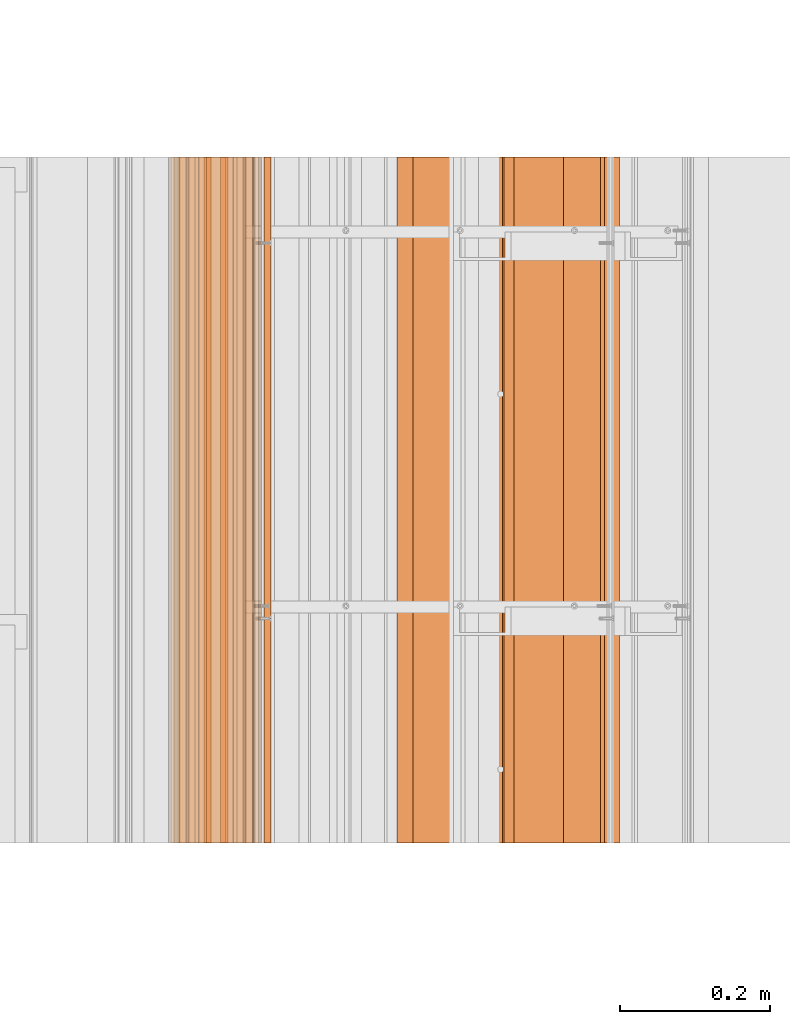
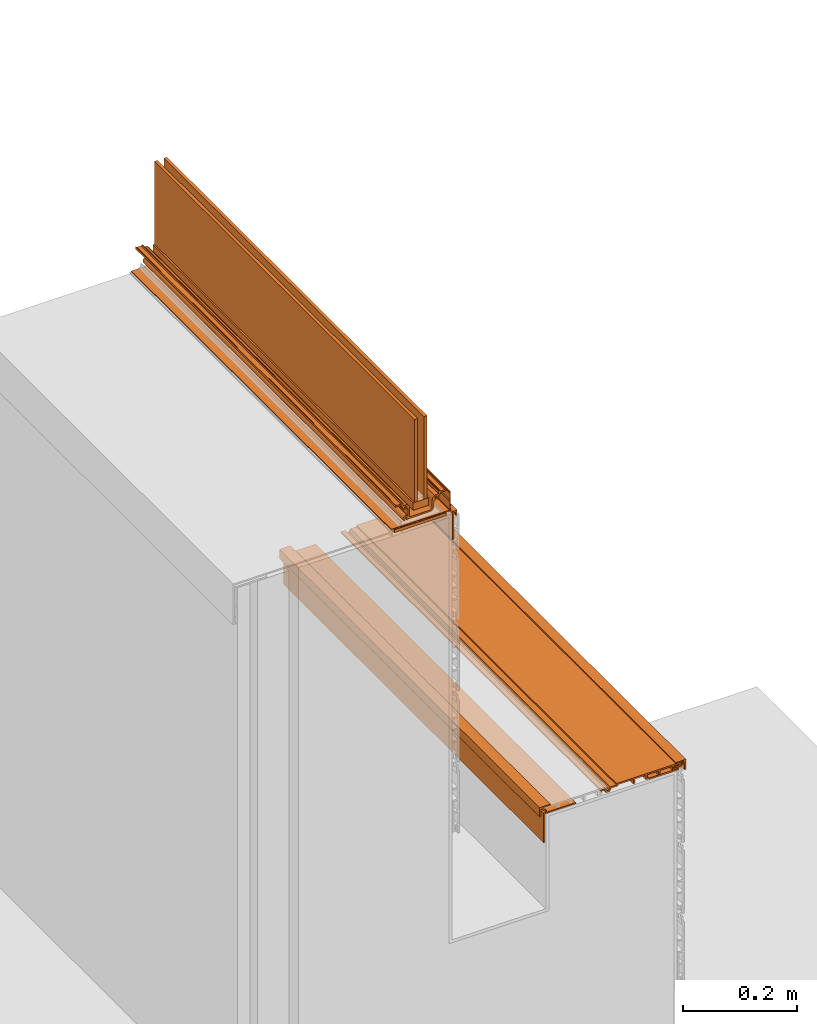
# One storey, part 5 of 36: 12 proxies.
"""IFC2X3 building model written with IfcOpenShell, lengths in feet."""

from ifc_helpers import new_model, entity, si_unit, converted_unit, derived_unit, direction, frame, frame_2d, origin, origin_2d_with_axis, place, context, subcontext, project, spatial, polyline, circle_curve, parameter, trimmed, segment, composite_curve, rectangle, outline, extrude, source, transform, mapped, material, type_object, type_shapes, element, save


model = new_model("IFC2X3")

# Units and contexts
model_context = context("Model", 3, precision=0.0001, world=origin(), true_north=direction((6.12303176911189e-17, 1.0)))
body_context = subcontext(model_context, "Body", "Model", "MODEL_VIEW")
ifc_project = project(units=[converted_unit("LENGTHUNIT", "FOOT", entity("IfcRatioMeasure", 0.3048), si_unit("LENGTHUNIT", "METRE"), dimensions=[1, 0, 0, 0, 0, 0, 0]), converted_unit("AREAUNIT", "SQUARE FOOT", entity("IfcRatioMeasure", 0.09290304), si_unit("AREAUNIT", "SQUARE_METRE"), dimensions=[2, 0, 0, 0, 0, 0, 0]), converted_unit("VOLUMEUNIT", "CUBIC FOOT", entity("IfcRatioMeasure", 0.028316846592), si_unit("VOLUMEUNIT", "CUBIC_METRE"), dimensions=[3, 0, 0, 0, 0, 0, 0]), converted_unit("PLANEANGLEUNIT", "DEGREE", entity("IfcRatioMeasure", 0.0174532925199433), si_unit("PLANEANGLEUNIT", "RADIAN"), dimensions=[0, 0, 0, 0, 0, 0, 0]), si_unit("MASSUNIT", "GRAM", prefix="KILO"), derived_unit("MASSDENSITYUNIT", [(si_unit("MASSUNIT", "GRAM", prefix="KILO"), 1), (si_unit("LENGTHUNIT", "METRE"), -3)]), si_unit("TIMEUNIT", "SECOND"), si_unit("FREQUENCYUNIT", "HERTZ"), si_unit("THERMODYNAMICTEMPERATUREUNIT", "DEGREE_CELSIUS"), derived_unit("THERMALTRANSMITTANCEUNIT", [(si_unit("MASSUNIT", "GRAM", prefix="KILO"), 1), (si_unit("THERMODYNAMICTEMPERATUREUNIT", "KELVIN"), -1), (si_unit("TIMEUNIT", "SECOND"), -3)]), derived_unit("VOLUMETRICFLOWRATEUNIT", [(si_unit("LENGTHUNIT", "METRE"), 3), (si_unit("TIMEUNIT", "SECOND"), -1)]), si_unit("ELECTRICCURRENTUNIT", "AMPERE"), si_unit("ELECTRICVOLTAGEUNIT", "VOLT"), si_unit("POWERUNIT", "WATT"), si_unit("FORCEUNIT", "NEWTON"), si_unit("ILLUMINANCEUNIT", "LUX"), si_unit("LUMINOUSFLUXUNIT", "LUMEN"), si_unit("LUMINOUSINTENSITYUNIT", "CANDELA"), derived_unit("USERDEFINED", [(si_unit("MASSUNIT", "GRAM", prefix="KILO"), -1), (si_unit("LENGTHUNIT", "METRE"), -2), (si_unit("TIMEUNIT", "SECOND"), 3), (si_unit("LUMINOUSFLUXUNIT", "LUMEN"), 1)]), derived_unit("LINEARVELOCITYUNIT", [(si_unit("LENGTHUNIT", "METRE"), 1), (si_unit("TIMEUNIT", "SECOND"), -1)]), si_unit("PRESSUREUNIT", "PASCAL"), derived_unit("USERDEFINED", [(si_unit("LENGTHUNIT", "METRE"), -2), (si_unit("MASSUNIT", "GRAM", prefix="KILO"), 1), (si_unit("TIMEUNIT", "SECOND"), -2)])], contexts=[model_context])

# Site, building, storey
site_placement = place(None, origin())
site = spatial("IfcSite", under=ifc_project, at=site_placement, CompositionType="ELEMENT")
building_placement = place(site_placement, origin())
building = spatial("IfcBuilding", under=site, at=building_placement, CompositionType="ELEMENT")
storey_placement = place(building_placement, origin())
storey = spatial("IfcBuildingStorey", under=building, at=storey_placement, Name="Level 1", CompositionType="ELEMENT", Elevation=0.0)

# Proxies
ifc_material_1 = material(Name="_EXISTING CAST-IN-PLACE CONCRETE")
building_element_proxy_type_1 = type_object("IfcBuildingElementProxyType", Name="starter strip 016", PredefinedType="NOTDEFINED", material=ifc_material_1)
shared_shape_1 = source(origin(), body_context, "Body", "SweptSolid", [
    extrude(outline(polyline([(-0.00592609117454401, -0.050489778625332), (-0.00592609117454401, -0.0251609571030125), (-0.0154211444225609, -0.0251609571030125), (-0.0154211444225609, -0.0613594856463298), (0.0159630966207516, -0.0613594856463298), (0.0159630966207516, 0.137010221374674), (0.005384138976396, 0.137010221374674), (0.005384138976396, -0.050489778625332), (-0.00592609117454401, -0.050489778625332)])), frame((123.583785406736, -64.2284331589239, 4.30650615626973), z_axis=(0.0, -1.0, 0.0), x_axis=(-1.0, 0.0, 0.0)), (0.0, 0.0, -1.0), 3.0),
])
type_shapes(building_element_proxy_type_1, [shared_shape_1])
proxy_1_placement = place(storey_placement, origin())
element("IfcBuildingElementProxy", 1, at=proxy_1_placement, inside=storey, type_object=building_element_proxy_type_1, material=ifc_material_1, Name="starter strip 016:starter strip 016", ObjectType="starter strip 016", context=body_context, shape_type="MappedRepresentation", body=[
    mapped(shared_shape_1, transform((0.0, 0.0, 0.0), scale=1.0)),
])
building_element_proxy_type_2 = type_object("IfcBuildingElementProxyType", Name="starter strip 017", PredefinedType="NOTDEFINED", material=ifc_material_1)
shared_shape_2 = source(origin(), body_context, "Body", "SweptSolid", [
    extrude(outline(polyline([(-0.0154211442749248, -0.0613594857283459), (0.0159630965387136, -0.0613594857283459), (0.0159630965387136, 0.137010221423893), (0.00538413886154165, 0.137010221423893), (0.00538413886154165, -0.0504897785761358), (-0.00592609112533005, -0.0504897785761358), (-0.00592609112533005, -0.0251609571194393), (-0.0154211442749248, -0.0251609571194393), (-0.0154211442749248, -0.0613594857283459)])), frame((125.015685607566, -64.2284331589239, 2.03863767952562), z_axis=(0.0, 1.0, 0.0), x_axis=(0.0, 0.0, -1.0)), (0.0, 0.0, 1.0), 3.0),
])
type_shapes(building_element_proxy_type_2, [shared_shape_2])
proxy_2_placement = place(storey_placement, origin())
element("IfcBuildingElementProxy", 2, at=proxy_2_placement, inside=storey, type_object=building_element_proxy_type_2, material=ifc_material_1, Name="starter strip 017:starter strip 017", ObjectType="starter strip 017", context=body_context, shape_type="MappedRepresentation", body=[
    mapped(shared_shape_2, transform((0.0, 0.0, 0.0), scale=1.0)),
])
building_element_proxy_type_3 = type_object("IfcBuildingElementProxyType", Name="panel 055", PredefinedType="NOTDEFINED", material=ifc_material_1)
shared_shape_3 = source(origin(), body_context, "Body", "SweptSolid", [
    extrude(outline(polyline([(-0.291819852941188, -0.0116008650030928), (-0.291819852941188, -0.0220175316697455), (0.14568014705884, -0.0220175316697455), (0.14568014705884, -0.0116008650030928), (0.187346813725497, -0.0116008650030928), (0.195644309526017, 0.00619317207041803), (0.210299317924978, 0.00619317207041803), (0.218596813725497, -0.0116008650030928), (0.249846813725512, -0.0116008650030928), (0.249846813725512, -0.00118419833641559), (0.225232962281922, -0.00118419833641559), (0.2159940266192, 0.0186287629496666), (0.189949600831795, 0.0186287629496666), (0.180710665169073, -0.00118419833641559), (0.135263480392155, -0.00118419833641559), (0.135263480392155, -0.0116008650030928), (0.0337009803921404, -0.0116008650030928), (0.0337009803921404, 0.019649134996913), (0.0232843137255117, 0.019649134996913), (0.0232843137255117, -0.0116008650030928), (-0.0496323529411598, -0.0116008650030928), (-0.0496323529411598, 0.019649134996913), (-0.0600490196078454, 0.019649134996913), (-0.0600490196078454, -0.0116008650030928), (-0.132965686274503, -0.0116008650030928), (-0.132965686274503, 0.019649134996913), (-0.143382352941174, 0.019649134996913), (-0.143382352941174, -0.0116008650030928), (-0.226715686274517, -0.0116008650030928), (-0.226715686274517, 0.0173047731202809), (-0.257965686274503, 0.0173047731202809), (-0.257965686274503, 0.00451787023313122), (-0.23713235294116, 0.00451787023313122), (-0.23713235294116, -0.0116008650030928), (-0.291819852941188, -0.0116008650030928)])), frame((124.806318378411, -64.2284331589239, 2.04908164088408), z_axis=(0.0, -1.0, 0.0), x_axis=(-1.0, 0.0, 0.0)), (0.0, 0.0, -1.0), 3.0),
])
type_shapes(building_element_proxy_type_3, [shared_shape_3])
proxy_3_placement = place(storey_placement, origin())
element("IfcBuildingElementProxy", 3, at=proxy_3_placement, inside=storey, type_object=building_element_proxy_type_3, material=ifc_material_1, Name="panel 055:panel 055", ObjectType="panel 055", context=body_context, shape_type="MappedRepresentation", body=[
    mapped(shared_shape_3, transform((0.0, 0.0, 0.0), scale=1.0)),
])
ifc_material_2 = material()
building_element_proxy_type_4 = type_object("IfcBuildingElementProxyType", Name="corner piece 003", PredefinedType="NOTDEFINED", material=ifc_material_2)
shared_shape_4 = source(origin(), body_context, "Body", "SweptSolid", [
    extrude(outline(polyline([(-0.0149053617383146, 0.0207413378931518), (0.0387187209388884, 0.0207413378931518), (0.0387187209388884, 0.0296314848682178), (-0.0270046081293742, 0.0296314848682178), (-0.0270046081293742, -0.0417584218082911), (-0.0181144611477606, -0.0417584218082911), (-0.0181144611477606, 0.0113778707507861), (0.0107098875694476, -0.0174464779664261), (0.0169961708453599, -0.0111601946905187), (-0.0149053617383146, 0.0207413378931518)])), frame((125.095319204193, -64.2284331589239, 2.05067492123086), z_axis=(0.0, 1.0, 0.0), x_axis=(-1.0, 0.0, 0.0)), (0.0, 0.0, 1.0), 3.0),
])
type_shapes(building_element_proxy_type_4, [shared_shape_4])
proxy_4_placement = place(storey_placement, origin())
element("IfcBuildingElementProxy", 4, at=proxy_4_placement, inside=storey, type_object=building_element_proxy_type_4, material=ifc_material_2, Name="corner piece 003:corner piece 003", ObjectType="corner piece 003", context=body_context, shape_type="MappedRepresentation", body=[
    mapped(shared_shape_4, transform((0.0, 0.0, 0.0), scale=1.0)),
])
building_element_proxy_type_5 = type_object("IfcBuildingElementProxyType", Name="corner piece 004", PredefinedType="NOTDEFINED", material=ifc_material_1)
shared_shape_5 = source(origin(), body_context, "Body", "SweptSolid", [
    extrude(outline(polyline([(-0.0149053617383155, 0.0207413378931705), (0.0387187209388906, 0.0207413378931705), (0.0387187209388906, 0.0296314848682329), (-0.0270046081293813, 0.0296314848682329), (-0.0270046081293813, -0.0417584218082681), (-0.0181144611477593, -0.0417584218082681), (-0.0181144611477593, 0.0113778707508203), (0.0107098875694533, -0.0174464779664021), (0.0169961708453585, -0.011160194690504), (-0.0149053617383155, 0.0207413378931705)])), frame((124.178314795223, -64.2284331589239, 2.05330179796957), z_axis=(0.0, 1.0, 0.0), x_axis=(0.0, 0.0, -1.0)), (0.0, 0.0, 1.0), 3.0),
])
type_shapes(building_element_proxy_type_5, [shared_shape_5])
proxy_5_placement = place(storey_placement, origin())
element("IfcBuildingElementProxy", 5, at=proxy_5_placement, inside=storey, type_object=building_element_proxy_type_5, material=ifc_material_1, Name="corner piece 004:corner piece 004", ObjectType="corner piece 004", context=body_context, shape_type="MappedRepresentation", body=[
    mapped(shared_shape_5, transform((0.0, 0.0, 0.0), scale=1.0)),
])
building_element_proxy_type_6 = type_object("IfcBuildingElementProxyType", Name="Corner piece 004", PredefinedType="NOTDEFINED", material=ifc_material_1)
shared_shape_6 = source(origin(), body_context, "Body", "SweptSolid", [
    extrude(outline(polyline([(-0.0729575182633422, -0.140467365704282), (-0.0632016241360458, -0.140467365704282), (-0.0632016241360458, 0.0660140870516273), (0.136159142399388, 0.0660140870516273), (0.136159142399388, 0.0744532786526833), (-0.0729575182633422, 0.0744532786526833), (-0.0729575182633422, -0.140467365704282)])), frame((124.249247933331, -64.2284331589239, 1.95950617734236), z_axis=(0.0, 1.0, 0.0), x_axis=(0.0, 0.0, -1.0)), (0.0, 0.0, 1.0), 3.0),
])
type_shapes(building_element_proxy_type_6, [shared_shape_6])
proxy_6_placement = place(storey_placement, origin())
element("IfcBuildingElementProxy", 6, at=proxy_6_placement, inside=storey, type_object=building_element_proxy_type_6, material=ifc_material_1, Name="Corner piece 004:Corner piece 004", ObjectType="Corner piece 004", context=body_context, shape_type="MappedRepresentation", body=[
    mapped(shared_shape_6, transform((0.0, 0.0, 0.0), scale=1.0)),
])
ifc_material_3 = material(Name="Window frame")
building_element_proxy_type_7 = type_object("IfcBuildingElementProxyType", Name="Window frame 089", PredefinedType="NOTDEFINED", material=ifc_material_3)
shared_shape_7 = source(origin(), body_context, "Body", "SweptSolid", [
    extrude(rectangle(XDim=3.0, YDim=0.104166666666671, at=frame_2d((0.0, 7.105427357601e-15), x_axis=(1.0, 0.0))), frame((123.357276021148, -62.7284331589239, 4.46866666666667), z_axis=(0.0, 0.0, 1.0), x_axis=(0.0, 1.0, 0.0)), (0.0, 0.0, 1.0), 0.052083333333333),
])
type_shapes(building_element_proxy_type_7, [shared_shape_7])
proxy_7_placement = place(storey_placement, origin())
element("IfcBuildingElementProxy", 7, at=proxy_7_placement, inside=storey, type_object=building_element_proxy_type_7, material=ifc_material_3, Name="Window frame 089:Window frame 089", ObjectType="Window frame 089", context=body_context, shape_type="MappedRepresentation", body=[
    mapped(shared_shape_7, transform((0.0, 0.0, 0.0), scale=1.0)),
])
building_element_proxy_type_8 = type_object("IfcBuildingElementProxyType", Name="Window frame 090", PredefinedType="NOTDEFINED", material=ifc_material_3)
shared_shape_8 = source(origin(), body_context, "Body", "SweptSolid", [
    extrude(outline(composite_curve([segment(trimmed(circle_curve(frame_2d((-0.0658911747436523, -0.0703032950578303), x_axis=(1.0, 0.0)), 0.00166666666666672), [parameter(180.00000000003)], [parameter(270.0)], True, "PARAMETER"), False, "CONTINUOUS"), segment(polyline([(-0.0675578414103175, -0.0703032950578322), (-0.0675578414103466, -0.0028329074779599)]), True, "CONTINUOUS"), segment(trimmed(circle_curve(frame_2d((-0.0883911744315764, -0.00283290747797239), x_axis=(1.0, 0.0)), 0.0208333330212257), [parameter(359.999999999998)], [parameter(45.0000020853816)], True, "PARAMETER"), True, "CONTINUOUS"), segment(polyline([(-0.0736597839137337, 0.0118984841122385), (-0.084231693077015, 0.0217800382757486)]), True, "CONTINUOUS"), segment(polyline([(-0.084231693077015, 0.0217800382757486), (-0.108641174743724, 0.0217800382757329)]), True, "CONTINUOUS"), segment(trimmed(circle_curve(frame_2d((-0.108641174743725, 0.0234467049422942), x_axis=(1.0, 0.0)), 0.0016666666666672), [parameter(180.00000000003)], [parameter(270.0)], True, "PARAMETER"), False, "CONTINUOUS"), segment(polyline([(-0.11030784141039, 0.0234467049422922), (-0.110307841410385, 0.0385300382755134)]), True, "CONTINUOUS"), segment(trimmed(circle_curve(frame_2d((-0.114474508077077, 0.0385300382755116), x_axis=(1.0, 0.0)), 0.0041666666666667), [parameter(359.999999999988)], [parameter(90.0000000000001)], True, "PARAMETER"), True, "CONTINUOUS"), segment(polyline([(-0.114474508077079, 0.0426967049421772), (-0.118474508077056, 0.042696704942394)]), True, "CONTINUOUS"), segment(polyline([(-0.118474508077056, 0.042696704942394), (-0.12364117474372, 0.037530038275723)]), True, "CONTINUOUS"), segment(polyline([(-0.12364117474372, 0.037530038275723), (-0.151807841410384, 0.0375300382757049)]), True, "CONTINUOUS"), segment(polyline([(-0.151807841410384, 0.0375300382757049), (-0.156974508077055, 0.0426967049423693)]), True, "CONTINUOUS"), segment(polyline([(-0.156974508077055, 0.0426967049423693), (-0.160224508077063, 0.0426967049423672)]), True, "CONTINUOUS"), segment(polyline([(-0.160224508077063, 0.0426967049423672), (-0.160224508077053, 0.0271133716090343)]), True, "CONTINUOUS"), segment(polyline([(-0.160224508077053, 0.0271133716090343), (-0.122665954720279, 0.0271133716090584)]), True, "CONTINUOUS"), segment(trimmed(circle_curve(frame_2d((-0.122665954720278, 0.0254467048791239), x_axis=(1.0, 0.0)), 0.00166666672991144), [parameter(351.884069639977)], [parameter(90.0000000000001)], True, "PARAMETER"), False, "CONTINUOUS"), segment(trimmed(circle_curve(frame_2d((-0.108641175022726, 0.023446704593923), x_axis=(1.0, 0.0)), 0.012500000016576), [parameter(171.884069640064)], [parameter(252.081449951418)], True, "PARAMETER"), True, "CONTINUOUS"), segment(trimmed(circle_curve(frame_2d((-0.112999758196089, 0.00996719406824228), x_axis=(1.0, 0.0)), 0.00166666689156719), [parameter(343.826043026985)], [parameter(72.0814499516194)], True, "PARAMETER"), False, "CONTINUOUS"), segment(trimmed(circle_curve(frame_2d((-0.0933911748165626, 0.00428003781079634), x_axis=(1.0, 0.0)), 0.0187500000364705), [parameter(163.826043027054)], [parameter(227.723251394449)], True, "PARAMETER"), True, "CONTINUOUS"), segment(trimmed(circle_curve(frame_2d((-0.103099776528776, -0.00521996192994357), x_axis=(1.0, 0.0)), 0.00525000015973839), [parameter(236.407228092321)], [parameter(44.3778044608868)], True, "PARAMETER"), True, "CONTINUOUS"), segment(trimmed(circle_curve(frame_2d((-0.0933911751602806, 0.00428003810657574), x_axis=(1.0, 0.0)), 0.00833333305511122), [parameter(315.622196553165)], [parameter(224.37780446094)], True, "PARAMETER"), False, "CONTINUOUS"), segment(trimmed(circle_curve(frame_2d((-0.0836825733976918, -0.0052199619791655), x_axis=(1.0, 0.0)), 0.00525000047599331), [parameter(135.622196553142)], [parameter(305.75345477759)], True, "PARAMETER"), True, "CONTINUOUS"), segment(trimmed(circle_curve(frame_2d((-0.0796411745694813, -0.010833105257873), x_axis=(1.0, 0.0)), 0.0016666664924809), [parameter(359.999999999969)], [parameter(125.75345477773)], True, "PARAMETER"), False, "CONTINUOUS"), segment(polyline([(-0.0779745080769986, -0.0108331052578728), (-0.0779745080769823, -0.0584609865886069)]), True, "CONTINUOUS"), segment(trimmed(circle_curve(frame_2d((-0.0796411747954744, -0.058460986588607), x_axis=(1.0, 0.0)), 0.00166666671849116), [parameter(227.664598135279)], [parameter(359.999999999969)], True, "PARAMETER"), False, "CONTINUOUS"), segment(trimmed(circle_curve(frame_2d((-0.0933911749192714, -0.0735532952940248), x_axis=(1.0, 0.0)), 0.0187500001364517), [parameter(47.6645981350295)], [parameter(227.723252098129)], True, "PARAMETER"), True, "CONTINUOUS"), segment(trimmed(circle_curve(frame_2d((-0.103099776528726, -0.0830532952634067), x_axis=(1.0, 0.0)), 0.00525000015973822), [parameter(236.407228097145)], [parameter(44.3778044608937)], True, "PARAMETER"), True, "CONTINUOUS"), segment(trimmed(circle_curve(frame_2d((-0.0933911751602306, -0.0735532952268865), x_axis=(1.0, 0.0)), 0.00833333305511122), [parameter(315.622195713456)], [parameter(224.37780446094)], True, "PARAMETER"), False, "CONTINUOUS"), segment(trimmed(circle_curve(frame_2d((-0.0836825735945901, -0.083053295398416), x_axis=(1.0, 0.0)), 0.00525000039511683), [parameter(135.622195713554)], [parameter(351.68713761868)], True, "PARAMETER"), True, "CONTINUOUS"), segment(polyline([(-0.078487733076844, -0.0838123317242647), (0.0669421585811381, -0.0823866283909048)]), True, "CONTINUOUS"), segment(trimmed(circle_curve(frame_2d((0.0669421585896899, -0.0553032950575712), x_axis=(1.0, 0.0)), 0.0270833333333325), [parameter(269.999999981902)], [parameter(359.999999999998)], True, "PARAMETER"), True, "CONTINUOUS"), segment(polyline([(0.094025491923027, -0.0553032950575548), (0.09402549192297, -0.0108331052577624)]), True, "CONTINUOUS"), segment(trimmed(circle_curve(frame_2d((0.0956921584154385, -0.0108331052577605), x_axis=(1.0, 0.0)), 0.0016666664924809), [parameter(54.2465478479916)], [parameter(180.00000000003)], True, "PARAMETER"), False, "CONTINUOUS"), segment(trimmed(circle_curve(frame_2d((0.0997335568270221, -0.00521996201522772), x_axis=(1.0, 0.0)), 0.00525000020334232), [parameter(234.246547848085)], [parameter(44.3778047850822)], True, "PARAMETER"), True, "CONTINUOUS"), segment(trimmed(circle_curve(frame_2d((0.109442158172951, 0.00428003810670594), x_axis=(1.0, 0.0)), 0.00833333305511122), [parameter(315.622195539056)], [parameter(224.377804785051)], True, "PARAMETER"), False, "CONTINUOUS"), segment(trimmed(circle_curve(frame_2d((0.119150759541472, -0.00521996192980091), x_axis=(1.0, 0.0)), 0.00525000015973832), [parameter(135.622195539093)], [parameter(303.592771911593)], True, "PARAMETER"), True, "CONTINUOUS"), segment(trimmed(circle_curve(frame_2d((0.109442158245867, 0.00428003847894862), x_axis=(1.0, 0.0)), 0.0187500002505323), [parameter(312.276746291442)], [parameter(16.1739563305649)], True, "PARAMETER"), True, "CONTINUOUS"), segment(trimmed(circle_curve(frame_2d((0.129050741625385, 0.0099671944980806), x_axis=(1.0, 0.0)), 0.00166666661104536), [parameter(107.918552186485)], [parameter(196.173956330626)], True, "PARAMETER"), False, "CONTINUOUS"), segment(trimmed(circle_curve(frame_2d((0.124692158035372, 0.0234467045940728), x_axis=(1.0, 0.0)), 0.0125000000165764), [parameter(287.918552186603)], [parameter(8.11593035993599)], True, "PARAMETER"), True, "CONTINUOUS"), segment(trimmed(circle_curve(frame_2d((0.138716937732921, 0.0254467048792917), x_axis=(1.0, 0.0)), 0.00166666672991128), [parameter(90.0000000000001)], [parameter(188.115930360022)], True, "PARAMETER"), False, "CONTINUOUS"), segment(polyline([(0.13871693773292, 0.0271133716092022), (0.176275491922976, 0.0271133716092503)]), True, "CONTINUOUS"), segment(polyline([(0.176275491922976, 0.0271133716092503), (0.176275491922966, 0.0426967049425832)]), True, "CONTINUOUS"), segment(polyline([(0.176275491922966, 0.0426967049425832), (0.173025491922943, 0.0426967049425811)]), True, "CONTINUOUS"), segment(polyline([(0.173025491922943, 0.0426967049425811), (0.167858825256293, 0.0375300382759101)]), True, "CONTINUOUS"), segment(polyline([(0.167858825256293, 0.0375300382759101), (0.139692158589629, 0.037530038275892)]), True, "CONTINUOUS"), segment(polyline([(0.139692158589629, 0.037530038275892), (0.134525491922944, 0.0426967049425564)]), True, "CONTINUOUS"), segment(polyline([(0.134525491922944, 0.0426967049425564), (0.130525491922954, 0.0426967049425538)]), True, "CONTINUOUS"), segment(trimmed(circle_curve(frame_2d((0.130525491922956, 0.0385300382756689), x_axis=(1.0, 0.0)), 0.0041666666666666), [parameter(90.0000000000001)], [parameter(180.000000000012)], True, "PARAMETER"), True, "CONTINUOUS"), segment(polyline([(0.126358825256293, 0.0385300382756653), (0.126358825256317, 0.0234467049424441)]), True, "CONTINUOUS"), segment(trimmed(circle_curve(frame_2d((0.124692158589638, 0.0234467049424439), x_axis=(1.0, 0.0)), 0.0016666666666672), [parameter(269.999999807518)], [parameter(359.999999999969)], True, "PARAMETER"), False, "CONTINUOUS"), segment(polyline([(0.12469215858404, 0.0217800382757761), (0.0991041652562791, 0.0212918824425327)]), True, "CONTINUOUS"), segment(polyline([(0.0991041652562791, 0.0212918824425336), (0.0897107671013581, 0.0118984842875659)]), True, "CONTINUOUS"), segment(trimmed(circle_curve(frame_2d((0.104442157860889, -0.0028329064718995), x_axis=(1.0, 0.0)), 0.0208333326045585), [parameter(135.000000000097)], [parameter(180.000000000002)], True, "PARAMETER"), True, "CONTINUOUS"), segment(polyline([(0.0836088252563361, -0.00283290647191377), (0.0836088252563556, -0.0553032950575614)]), True, "CONTINUOUS"), segment(trimmed(circle_curve(frame_2d((0.0669421585896899, -0.0553032950575712), x_axis=(1.0, 0.0)), 0.0166666666666662), [parameter(270.0)], [parameter(359.999999999997)], True, "PARAMETER"), False, "CONTINUOUS"), segment(polyline([(0.0669421585897006, -0.0719699617242388), (-0.0658911747436512, -0.0719699617242388)]), True, "CONTINUOUS")], self_intersect=False)), frame((123.349704261725, -64.2284331589239, 4.50263662839085), z_axis=(0.0, -1.0, 0.0), x_axis=(1.0, 0.0, 0.0)), (0.0, 0.0, -1.0), 3.0),
])
type_shapes(building_element_proxy_type_8, [shared_shape_8])
proxy_8_placement = place(storey_placement, origin())
element("IfcBuildingElementProxy", 8, at=proxy_8_placement, inside=storey, type_object=building_element_proxy_type_8, material=ifc_material_3, Name="Window frame 090:Window frame 090", ObjectType="Window frame 090", context=body_context, shape_type="MappedRepresentation", body=[
    mapped(shared_shape_8, transform((0.0, 0.0, 0.0), scale=1.0)),
])
ifc_material_4 = material(Name="Clear glass")
building_element_proxy_type_9 = type_object("IfcBuildingElementProxyType", Name="Glass panel 023", PredefinedType="NOTDEFINED", material=ifc_material_4)
shared_shape_9 = source(origin(), body_context, "Body", "SweptSolid", [
    extrude(rectangle(XDim=3.0, YDim=0.020833333333357, at=frame_2d((0.0, 7.105427357601e-15), x_axis=(1.0, 0.0))), frame((123.388665434482, -62.7284331589239, 4.52075), z_axis=(0.0, 0.0, 1.0), x_axis=(0.0, 1.0, 0.0)), (0.0, 0.0, 1.0), 0.5825376725),
])
type_shapes(building_element_proxy_type_9, [shared_shape_9])
proxy_9_placement = place(storey_placement, origin())
element("IfcBuildingElementProxy", 9, at=proxy_9_placement, inside=storey, type_object=building_element_proxy_type_9, material=ifc_material_4, Name="Glass panel 023:Glass panel 023", ObjectType="Glass panel 023", context=body_context, shape_type="MappedRepresentation", body=[
    mapped(shared_shape_9, transform((0.0, 0.0, 0.0), scale=1.0)),
])
building_element_proxy_type_10 = type_object("IfcBuildingElementProxyType", Name="Window frame 091", PredefinedType="NOTDEFINED", material=ifc_material_3)
shared_shape_10 = source(origin(), body_context, "Body", "SweptSolid", [
    extrude(outline(composite_curve([segment(polyline([(-0.0405729300053095, -0.0732855467511731), (-0.0317340952404813, -0.0732855467511731)]), True, "CONTINUOUS"), segment(polyline([(-0.0317340952404813, -0.0732855467511731), (-0.028080710204352, -0.0696321617150401)]), True, "CONTINUOUS"), segment(polyline([(-0.028080710204352, -0.0696321617150401), (-0.0280807102043507, -0.0607933269502018)]), True, "CONTINUOUS"), segment(polyline([(-0.0280807102043507, -0.0607933269502018), (0.0422764145236701, 0.00956379777788895)]), True, "CONTINUOUS"), segment(polyline([(0.0422764145236701, 0.00956379777788895), (0.0511152492884882, 0.0095637977778789)]), True, "CONTINUOUS"), segment(polyline([(0.0511152492884882, 0.0095637977778789), (0.0547686343246377, 0.013217182814032)]), True, "CONTINUOUS"), segment(polyline([(0.0547686343246377, 0.013217182814032), (0.0547686343246189, 0.0220560175788502)]), True, "CONTINUOUS"), segment(polyline([(0.0547686343246189, 0.0220560175788502), (0.0753925821092176, 0.0426799653634694)]), True, "CONTINUOUS"), segment(polyline([(0.0753925821092176, 0.0426799653634694), (0.0842314168740458, 0.0426799653634694)]), True, "CONTINUOUS"), segment(polyline([(0.0842314168740458, 0.0426799653634694), (0.0878848019101752, 0.0463333503996024)]), True, "CONTINUOUS"), segment(polyline([(0.0878848019101752, 0.0463333503996024), (0.0878848019101764, 0.0551721851644407)]), True, "CONTINUOUS"), segment(polyline([(0.0878848019101764, 0.0551721851644407), (0.158241926638197, 0.125529309892531)]), True, "CONTINUOUS"), segment(polyline([(0.158241926638197, 0.125529309892531), (0.167080761403035, 0.125529309892541)]), True, "CONTINUOUS"), segment(polyline([(0.167080761403035, 0.125529309892541), (0.170734146439165, 0.129182694928674)]), True, "CONTINUOUS"), segment(polyline([(0.170734146439165, 0.129182694928674), (0.170734146439156, 0.138021529693503)]), True, "CONTINUOUS"), segment(polyline([(0.170734146439156, 0.138021529693503), (0.20508775089177, 0.172375134146151)]), True, "CONTINUOUS"), segment(trimmed(circle_curve(frame_2d((0.202141472636874, 0.169428855891165), x_axis=(-0.707106781186198, -0.707106781186894)), 0.0041666666666667), [parameter(180.000000000843)], [parameter(270.0)], True, "PARAMETER"), True, "CONTINUOUS"), segment(polyline([(0.199195194381885, 0.172375134146151), (-0.0711552982916754, -0.0979753585275445)]), True, "CONTINUOUS"), segment(trimmed(circle_curve(frame_2d((-0.0748086833278091, -0.0943219734914145), x_axis=(-0.707106781186198, -0.707106781186894)), 0.00516666666666729), [parameter(9.87244173126277e-12)], [parameter(90.0000000000001)], True, "PARAMETER"), False, "CONTINUOUS"), segment(polyline([(-0.0784620683639579, -0.0979753585275682), (-0.114583439769522, -0.0618539871220404)]), True, "CONTINUOUS"), segment(polyline([(-0.114583439769522, -0.0618539871220404), (-0.114583439769499, -0.0530151523571833)]), True, "CONTINUOUS"), segment(polyline([(-0.114583439769499, -0.0530151523571833), (-0.118236824805632, -0.0493617673210539)]), True, "CONTINUOUS"), segment(polyline([(-0.118236824805632, -0.0493617673210539), (-0.127075659570489, -0.0493617673210853)]), True, "CONTINUOUS"), segment(polyline([(-0.127075659570489, -0.0493617673210853), (-0.163197030976121, -0.0132403959154897)]), True, "CONTINUOUS"), segment(polyline([(-0.163197030976121, -0.0132403959154897), (-0.160604306111637, -0.0106476710511)]), True, "CONTINUOUS"), segment(trimmed(circle_curve(frame_2d((-0.162430998629704, -0.00882097853303468), x_axis=(-0.707106781186198, -0.707106781186894)), 0.00258333333333355), [parameter(90.0000000000001)], [parameter(270.0)], True, "PARAMETER"), True, "CONTINUOUS"), segment(polyline([(-0.164257691147818, -0.00699428601492288), (-0.169796694267183, -0.0125332891342936)]), True, "CONTINUOUS"), segment(polyline([(-0.169796694267183, -0.0125332891342936), (-0.0748086833277391, -0.107521300073643)]), True, "CONTINUOUS"), segment(polyline([(-0.0748086833277391, -0.107521300073643), (-0.0648502628260389, -0.106401714336764)]), True, "CONTINUOUS"), segment(polyline([(-0.0648502628260389, -0.106401714336764), (-0.0611968777899095, -0.102748329300631)]), True, "CONTINUOUS"), segment(polyline([(-0.0611968777899095, -0.102748329300631), (-0.0611968777899083, -0.0939094945357923)]), True, "CONTINUOUS"), segment(polyline([(-0.0611968777899083, -0.0939094945357923), (-0.0405729300053095, -0.0732855467511731)]), True, "CONTINUOUS")], self_intersect=False)), frame((123.426223836805, -64.2284331589239, 4.40429797979798), z_axis=(0.0, 1.0, 0.0), x_axis=(-0.707106781186196, 0.0, -0.707106781186899)), (0.0, 0.0, 1.0), 3.0),
])
type_shapes(building_element_proxy_type_10, [shared_shape_10])
proxy_10_placement = place(storey_placement, origin())
element("IfcBuildingElementProxy", 10, at=proxy_10_placement, inside=storey, type_object=building_element_proxy_type_10, material=ifc_material_3, Name="Window frame 091:Window frame 091", ObjectType="Window frame 091", context=body_context, shape_type="MappedRepresentation", body=[
    mapped(shared_shape_10, transform((0.0, 0.0, 0.0), scale=1.0)),
])
building_element_proxy_type_11 = type_object("IfcBuildingElementProxyType", Name="Window frame 092", PredefinedType="NOTDEFINED", material=ifc_material_3)
shared_shape_11 = source(origin(), body_context, "Body", "SweptSolid", [
    extrude(rectangle(XDim=3.0, YDim=0.345545159999986, at=frame_2d((0.0, -7.105427357601e-15), x_axis=(1.0, 0.0))), frame((123.355511677815, -62.7284331589239, 4.354125), z_axis=(0.0, 0.0, 1.0), x_axis=(0.0, 1.0, 0.0)), (0.0, 0.0, 1.0), 0.0207916666666668),
])
type_shapes(building_element_proxy_type_11, [shared_shape_11])
proxy_11_placement = place(storey_placement, origin())
element("IfcBuildingElementProxy", 11, at=proxy_11_placement, inside=storey, type_object=building_element_proxy_type_11, material=ifc_material_3, Name="Window frame 092:Window frame 092", ObjectType="Window frame 092", context=body_context, shape_type="MappedRepresentation", body=[
    mapped(shared_shape_11, transform((0.0, 0.0, 0.0), scale=1.0)),
])
building_element_proxy_type_12 = type_object("IfcBuildingElementProxyType", Name="Glass panel 024", PredefinedType="NOTDEFINED", material=ifc_material_4)
shared_shape_12 = source(origin(), body_context, "Body", "SweptSolid", [
    extrude(rectangle(XDim=3.0, YDim=0.0208333333333428, at=origin_2d_with_axis()), frame((123.326165434482, -62.7284331589239, 4.52075), z_axis=(0.0, 0.0, 1.0), x_axis=(0.0, 1.0, 0.0)), (0.0, 0.0, 1.0), 0.5825376725),
])
type_shapes(building_element_proxy_type_12, [shared_shape_12])
proxy_12_placement = place(storey_placement, origin())
element("IfcBuildingElementProxy", 12, at=proxy_12_placement, inside=storey, type_object=building_element_proxy_type_12, material=ifc_material_4, Name="Glass panel 024:Glass panel 024", ObjectType="Glass panel 024", context=body_context, shape_type="MappedRepresentation", body=[
    mapped(shared_shape_12, transform((0.0, 0.0, 0.0), scale=1.0)),
])

save(model, "model.ifc")
